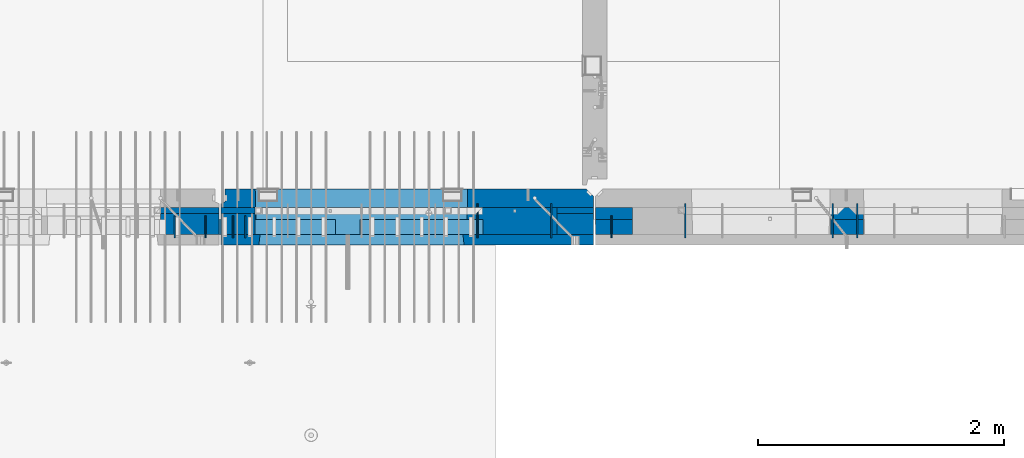
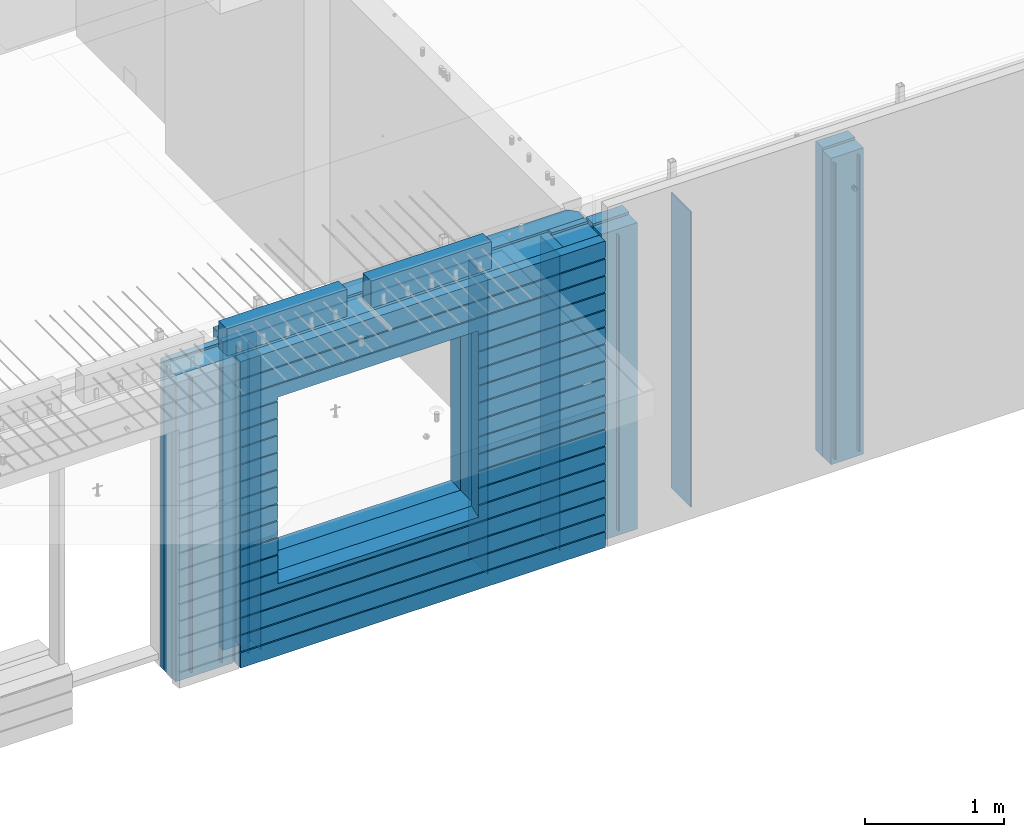
# One storey, part 198 of 309: 25 walls, 6 elements without a shape of their own.
"""IFC2X3 building model written with IfcOpenShell, lengths in millimetres."""

from ifc_helpers import new_model, si_unit, frame, origin_with_axes, place, context, subcontext, project, spatial, faceted_brep, material, type_object, element, aggregate, save


model = new_model("IFC2X3")

# Units and contexts
model_context = context("Model", 3, precision=1e-05, world=origin_with_axes())
body_context = subcontext(model_context, "Body", "Model", "MODEL_VIEW")
ifc_project = project(units=[si_unit("LENGTHUNIT", "METRE", prefix="MILLI"), si_unit("AREAUNIT", "SQUARE_METRE"), si_unit("VOLUMEUNIT", "CUBIC_METRE"), si_unit("MASSUNIT", "GRAM", prefix="KILO"), si_unit("TIMEUNIT", "SECOND"), si_unit("PLANEANGLEUNIT", "RADIAN"), si_unit("SOLIDANGLEUNIT", "STERADIAN"), si_unit("THERMODYNAMICTEMPERATUREUNIT", "DEGREE_CELSIUS"), si_unit("LUMINOUSINTENSITYUNIT", "LUMEN")], contexts=[model_context])

# Site, building, storey
site_placement = place(None, origin_with_axes())
site = spatial("IfcSite", under=ifc_project, at=site_placement, CompositionType="ELEMENT")
building_placement = place(site_placement, origin_with_axes())
building = spatial("IfcBuilding", under=site, at=building_placement, CompositionType="ELEMENT")
storey_placement = place(building_placement, origin_with_axes())
storey = spatial("IfcBuildingStorey", under=building, at=storey_placement, Name="7", CompositionType="ELEMENT", Elevation=0.0)

# Assembly, walls
assembly_1_placement = place(storey_placement, origin_with_axes())
assembly_1 = element("IfcElementAssembly", 1, at=assembly_1_placement, inside=storey, AssemblyPlace="NOTDEFINED", PredefinedType="REINFORCEMENT_UNIT")
ifc_material_1 = material(Name="Undefined")
wall_type_1 = type_object("IfcWallType", PredefinedType="NOTDEFINED")
wall_1_placement = place(assembly_1_placement, frame((25665.0, 7780.0, 101115.0), z_axis=(0.0, 0.0, 1.0), x_axis=(0.0, -1.0, 0.0)))
wall_1 = element("IfcWall", 2, at=wall_1_placement, type_object=wall_type_1, material=ifc_material_1, Name="(PD)", context=body_context, shape_type="Brep", body=[
    faceted_brep([(0.0, 5.0, -1300.0), (0.0, 5.0, 1300.0), (180.0, 5.0, 1300.0), (180.0, 5.0, -1300.0), (0.0, -5.0, 1300.0), (180.0, -5.0, 1300.0), (0.0, -5.0, -1300.0), (180.0, -5.0, -1300.0)], [[[0, 1, 2, 3]], [[1, 4, 5, 2]], [[4, 6, 7, 5]], [[6, 0, 3, 7]], [[5, 7, 3, 2]], [[6, 4, 1, 0]]]),
])
wall_2_placement = place(assembly_1_placement, frame((25765.0, 7780.0, 101115.0), z_axis=(0.0, 0.0, 1.0), x_axis=(0.0, -1.0, 0.0)))
wall_2 = element("IfcWall", 3, at=wall_2_placement, type_object=wall_type_1, material=ifc_material_1, Name="(PD)", context=body_context, shape_type="Brep", body=[
    faceted_brep([(0.0, 5.0, -1300.0), (0.0, 5.0, 1300.0), (180.0, 5.0, 1300.0), (180.0, 5.0, -1300.0), (0.0, -5.0, 1300.0), (180.0, -5.0, 1300.0), (0.0, -5.0, -1300.0), (180.0, -5.0, -1300.0)], [[[0, 1, 2, 3]], [[1, 4, 5, 2]], [[4, 6, 7, 5]], [[6, 0, 3, 7]], [[5, 7, 3, 2]], [[6, 4, 1, 0]]]),
])
wall_3_placement = place(assembly_1_placement, frame((28255.0, 7880.0, 101115.0), z_axis=(0.0, 0.0, 1.0), x_axis=(0.0, -1.0, 0.0)))
wall_3 = element("IfcWall", 4, at=wall_3_placement, type_object=wall_type_1, material=ifc_material_1, Name="(PD)", context=body_context, shape_type="Brep", body=[
    faceted_brep([(0.0, 5.0, -1300.0), (0.0, 5.0, 1300.0), (280.0, 5.0, 1300.0), (280.0, 5.0, -1300.0), (0.0, -5.0, 1300.0), (280.0, -5.0, 1300.0), (0.0, -5.0, -1300.0), (280.0, -5.0, -1300.0)], [[[0, 1, 2, 3]], [[1, 4, 5, 2]], [[4, 6, 7, 5]], [[6, 0, 3, 7]], [[5, 7, 3, 2]], [[6, 4, 1, 0]]]),
])

assembly_2_placement = place(storey_placement, origin_with_axes())
assembly_2 = element("IfcElementAssembly", 5, at=assembly_2_placement, inside=storey, AssemblyPlace="NOTDEFINED", PredefinedType="REINFORCEMENT_UNIT")
wall_4_placement = place(assembly_2_placement, frame((28745.0021834468, 7780.0, 101115.0), z_axis=(0.0, 0.0, 1.0), x_axis=(0.0, -1.0, 0.0)))
wall_4 = element("IfcWall", 6, at=wall_4_placement, type_object=wall_type_1, material=ifc_material_1, Name="(PD)", context=body_context, shape_type="Brep", body=[
    faceted_brep([(0.0, 5.0, -1300.0), (0.0, 5.0, 1300.0), (180.0, 5.0, 1300.0), (180.0, 5.0, -1300.0), (0.0, -5.0, 1300.0), (180.0, -5.0, 1300.0), (0.0, -5.0, -1300.0), (180.0, -5.0, -1300.0)], [[[0, 1, 2, 3]], [[1, 4, 5, 2]], [[4, 6, 7, 5]], [[6, 0, 3, 7]], [[5, 7, 3, 2]], [[6, 4, 1, 0]]]),
])
wall_5_placement = place(assembly_2_placement, frame((29345.0021834468, 7880.0, 101115.0), z_axis=(0.0, 0.0, 1.0), x_axis=(0.0, -1.0, 0.0)))
wall_5 = element("IfcWall", 7, at=wall_5_placement, type_object=wall_type_1, material=ifc_material_1, Name="(PD)", context=body_context, shape_type="Brep", body=[
    faceted_brep([(0.0, 5.0, -1300.0), (0.0, 5.0, 1300.0), (280.0, 5.0, 1300.0), (280.0, 5.0, -1300.0), (0.0, -5.0, 1300.0), (280.0, -5.0, 1300.0), (0.0, -5.0, -1300.0), (280.0, -5.0, -1300.0)], [[[0, 1, 2, 3]], [[1, 4, 5, 2]], [[4, 6, 7, 5]], [[6, 0, 3, 7]], [[5, 7, 3, 2]], [[6, 4, 1, 0]]]),
])
wall_6_placement = place(assembly_2_placement, frame((30545.0021834468, 7880.0, 101115.0), z_axis=(0.0, 0.0, 1.0), x_axis=(0.0, -1.0, 0.0)))
wall_6 = element("IfcWall", 8, at=wall_6_placement, type_object=wall_type_1, material=ifc_material_1, Name="(PD)", context=body_context, shape_type="Brep", body=[
    faceted_brep([(0.0, 5.0, -1300.0), (0.0, 5.0, 1300.0), (280.0, 5.0, 1300.0), (280.0, 5.0, -1300.0), (0.0, -5.0, 1300.0), (280.0, -5.0, 1300.0), (0.0, -5.0, -1300.0), (280.0, -5.0, -1300.0)], [[[0, 1, 2, 3]], [[1, 4, 5, 2]], [[4, 6, 7, 5]], [[6, 0, 3, 7]], [[5, 7, 3, 2]], [[6, 4, 1, 0]]]),
])
wall_7_placement = place(assembly_2_placement, frame((30745.0021834468, 7880.0, 101115.0), z_axis=(0.0, 0.0, 1.0), x_axis=(0.0, -1.0, 0.0)))
wall_7 = element("IfcWall", 9, at=wall_7_placement, type_object=wall_type_1, material=ifc_material_1, Name="(PD)", context=body_context, shape_type="Brep", body=[
    faceted_brep([(0.0, 5.0, -1300.0), (0.0, 5.0, 1300.0), (280.0, 5.0, 1300.0), (280.0, 5.0, -1300.0), (0.0, -5.0, 1300.0), (280.0, -5.0, 1300.0), (0.0, -5.0, -1300.0), (280.0, -5.0, -1300.0)], [[[0, 1, 2, 3]], [[1, 4, 5, 2]], [[4, 6, 7, 5]], [[6, 0, 3, 7]], [[5, 7, 3, 2]], [[6, 4, 1, 0]]]),
])

assembly_3_placement = place(storey_placement, origin_with_axes())
assembly_3 = element("IfcElementAssembly", 10, at=assembly_3_placement, inside=storey, AssemblyPlace="NOTDEFINED", PredefinedType="REINFORCEMENT_UNIT")
wall_8_placement = place(assembly_3_placement, frame((25190.0, 7780.0, 101115.0), z_axis=(0.0, 0.0, 1.0), x_axis=(0.0, -1.0, 0.0)))
wall_8 = element("IfcWall", 11, at=wall_8_placement, type_object=wall_type_1, material=ifc_material_1, Name="(PD)", context=body_context, shape_type="Brep", body=[
    faceted_brep([(0.0, 5.0, -1300.0), (0.0, 5.0, 1300.0), (180.0, 5.0, 1300.0), (180.0, 5.0, -1300.0), (0.0, -5.0, 1300.0), (180.0, -5.0, 1300.0), (0.0, -5.0, -1300.0), (180.0, -5.0, -1300.0)], [[[0, 1, 2, 3]], [[1, 4, 5, 2]], [[4, 6, 7, 5]], [[6, 0, 3, 7]], [[5, 7, 3, 2]], [[6, 4, 1, 0]]]),
])
wall_9_placement = place(assembly_3_placement, frame((25440.0, 7780.0, 101115.0), z_axis=(0.0, 0.0, 1.0), x_axis=(0.0, -1.0, 0.0)))
wall_9 = element("IfcWall", 12, at=wall_9_placement, type_object=wall_type_1, material=ifc_material_1, Name="(PD)", context=body_context, shape_type="Brep", body=[
    faceted_brep([(0.0, 5.0, -1300.0), (0.0, 5.0, 1300.0), (180.0, 5.0, 1300.0), (180.0, 5.0, -1300.0), (0.0, -5.0, 1300.0), (180.0, -5.0, 1300.0), (0.0, -5.0, -1300.0), (180.0, -5.0, -1300.0)], [[[0, 1, 2, 3]], [[1, 4, 5, 2]], [[4, 6, 7, 5]], [[6, 0, 3, 7]], [[5, 7, 3, 2]], [[6, 4, 1, 0]]]),
])

# Wall
wall_10_placement = place(assembly_1_placement, frame((27655.0, 7880.0, 101115.0), z_axis=(0.0, 0.0, 1.0), x_axis=(0.0, -1.0, 0.0)))
wall_10 = element("IfcWall", 13, at=wall_10_placement, type_object=wall_type_1, material=ifc_material_1, Name="(PD)", context=body_context, shape_type="Brep", body=[
    faceted_brep([(0.0, 5.0, -1300.0), (0.0, 5.0, 1300.0), (280.0, 5.0, 1300.0), (280.0, 5.0, -1300.0), (0.0, -5.0, 1300.0), (280.0, -5.0, 1300.0), (0.0, -5.0, -1300.0), (280.0, -5.0, -1300.0)], [[[0, 1, 2, 3]], [[1, 4, 5, 2]], [[4, 6, 7, 5]], [[6, 0, 3, 7]], [[5, 7, 3, 2]], [[6, 4, 1, 0]]]),
])

# Assemblies, walls
assembly_4_placement = place(storey_placement, origin_with_axes())
assembly_4 = element("IfcElementAssembly", 14, at=assembly_4_placement, inside=storey, AssemblyPlace="NOTDEFINED", PredefinedType="REINFORCEMENT_UNIT")
assembly_5_placement = place(assembly_4_placement, origin_with_axes())
assembly_5 = element("IfcElementAssembly", 15, at=assembly_5_placement, Name="Steel Assembly", AssemblyPlace="NOTDEFINED", PredefinedType="NOTDEFINED")
ifc_material_2 = material()
wall_type_2 = type_object("IfcWallType", PredefinedType="NOTDEFINED")
wall_11_placement = place(assembly_5_placement, frame((26699.9998568133, 7690.00021946163, 102590.0), z_axis=(0.0, 0.0, 1.0), x_axis=(1.0, 0.0, 0.0)))
wall_11 = element("IfcWall", 16, at=wall_11_placement, type_object=wall_type_2, material=ifc_material_2, context=body_context, shape_type="Brep", body=[
    faceted_brep([(0.0, 60.0, -120.0), (0.0, 60.0, 120.0), (1000.0, 60.0, 120.0), (1000.0, 60.0, -120.0), (0.0, -60.0, 120.0), (1000.0, -60.0, 120.0), (0.0, -60.0, -120.0), (1000.0, -60.0, -120.0)], [[[0, 1, 2, 3]], [[1, 4, 5, 2]], [[4, 6, 7, 5]], [[6, 0, 3, 7]], [[5, 7, 3, 2]], [[6, 4, 1, 0]]]),
])
aggregate(assembly_5, [wall_11])
assembly_6_placement = place(assembly_4_placement, origin_with_axes())
assembly_6 = element("IfcElementAssembly", 17, at=assembly_6_placement, Name="Steel Assembly", AssemblyPlace="NOTDEFINED", PredefinedType="NOTDEFINED")
aggregate(assembly_4, [assembly_5, assembly_6])
wall_12_placement = place(assembly_6_placement, frame((25499.9998568133, 7690.00021946163, 102590.0), z_axis=(0.0, 0.0, 1.0), x_axis=(1.0, 0.0, 0.0)))
wall_12 = element("IfcWall", 18, at=wall_12_placement, type_object=wall_type_2, material=ifc_material_2, context=body_context, shape_type="Brep", body=[
    faceted_brep([(0.0, 60.0, -120.0), (0.0, 60.0, 120.0), (1000.0, 60.0, 120.0), (1000.0, 60.0, -120.0), (0.0, -60.0, 120.0), (1000.0, -60.0, 120.0), (0.0, -60.0, -120.0), (1000.0, -60.0, -120.0)], [[[0, 1, 2, 3]], [[1, 4, 5, 2]], [[4, 6, 7, 5]], [[6, 0, 3, 7]], [[5, 7, 3, 2]], [[6, 4, 1, 0]]]),
])
aggregate(assembly_6, [wall_12])

# Wall
ifc_material_3 = material(Name="CONCRETE/C35/45")
wall_type_3 = type_object("IfcWallType", PredefinedType="NOTDEFINED")
wall_13_placement = place(assembly_1_placement, frame((28600.0, 7925.0, 101112.5), z_axis=(0.0, 0.0, 1.0), x_axis=(-1.0, 3.00000001838171e-08, 0.0)))
wall_13 = element("IfcWall", 19, at=wall_13_placement, type_object=wall_type_3, material=ifc_material_3, context=body_context, shape_type="Brep", body=[
    faceted_brep([(0.0, 75.0, 1357.5), (0.0, 75.0, -1357.5), (0.0, -15.0, -1357.5), (0.0, -15.0, 1357.5), (60.0, -75.0, -1357.5), (3035.00000000003, 75.0, -1357.5), (3035.00000000003, 45.0, -1357.5), (3002.5, 32.0, -1357.5), (3002.5, -75.0, -1357.5), (60.0, -75.0, 1357.5), (3035.00000000003, 45.0, 1357.5), (3035.00000000003, 75.0, 1357.5), (3002.5, -75.0, 1357.5), (3002.5, 32.0, 1357.5), (2755.00051719707, -75.0, -682.5), (1025.00051719707, -75.0, -682.5), (1025.00051719707, -75.0, 952.5), (2755.00051719707, -75.0, 952.5), (2750.94646314301, 75.0, -678.445945945947), (1029.05457125112, 75.0, -678.445945945947), (1029.05457125112, 75.0, 948.445945945947), (2750.94646314301, 75.0, 948.445945945947)], [[[0, 1, 2, 3]], [[4, 2, 1, 5, 6, 7, 8]], [[3, 2, 4, 9]], [[10, 11, 0, 3, 9, 12, 13]], [[5, 11, 10, 6]], [[13, 7, 6, 10]], [[12, 8, 7, 13]], [[9, 4, 8, 12], [14, 15, 16, 17]], [[14, 18, 19, 15]], [[15, 19, 20, 16]], [[1, 0, 11, 5], [18, 21, 20, 19]], [[16, 20, 21, 17]], [[18, 14, 17, 21]]]),
])

wall_type_4 = type_object("IfcWallType", PredefinedType="NOTDEFINED")
wall_14_placement = place(assembly_2_placement, frame((30795.0000381475, 7800.0, 101112.5), z_axis=(0.0, 0.0, 1.0), x_axis=(-1.0, 3.00000001838171e-08, 0.0)))
wall_14 = element("IfcWall", 20, at=wall_14_placement, type_object=wall_type_4, material=ifc_material_3, context=body_context, shape_type="Brep", body=[
    faceted_brep([(0.0, 50.0, -1357.5), (0.0, 50.0, 1357.5), (270.001908754726, 50.0, 1357.5), (270.001908754726, 50.0, -1357.5), (0.0, -50.0, 1357.5), (270.001908754726, -50.0, 1357.5), (0.0, -50.0, -1357.5), (270.001908754726, -50.0, -1357.5)], [[[0, 1, 2, 3]], [[1, 4, 5, 2]], [[4, 6, 7, 5]], [[6, 0, 3, 7]], [[5, 7, 3, 2]], [[6, 4, 1, 0]]]),
])

wall_15_placement = place(assembly_2_placement, frame((28915.0000381475, 7800.0, 101112.5), z_axis=(0.0, 0.0, 1.0), x_axis=(-1.0, 3.00000001838171e-08, 0.0)))
wall_15 = element("IfcWall", 21, at=wall_15_placement, type_object=wall_type_4, material=ifc_material_3, context=body_context, shape_type="Brep", body=[
    faceted_brep([(0.0, 50.0, -1357.5), (0.0, 50.0, 1357.5), (300.001908754726, 50.0, 1357.5), (300.001908754726, 50.0, -1357.5), (0.0, -50.0, 1357.5), (300.001908754726, -50.0, 1357.5), (0.0, -50.0, -1357.5), (300.001908754726, -50.0, -1357.5)], [[[0, 1, 2, 3]], [[1, 4, 5, 2]], [[4, 6, 7, 5]], [[6, 0, 3, 7]], [[5, 7, 3, 2]], [[6, 4, 1, 0]]]),
])

ifc_material_4 = material(Name="SPU")
wall_type_5 = type_object("IfcWallType", PredefinedType="NOTDEFINED")
wall_16_placement = place(assembly_2_placement, frame((30795.0000381475, 7690.0, 101102.5), z_axis=(0.0, 0.0, 1.0), x_axis=(-1.0, 3.00000001838171e-08, 0.0)))
wall_16 = element("IfcWall", 22, at=wall_16_placement, type_object=wall_type_5, material=ifc_material_4, context=body_context, shape_type="Brep", body=[
    faceted_brep([(0.0, 60.0, -1347.5), (0.0, 60.0, 1347.5), (270.001908754726, 60.0, 1347.5), (270.001908754726, 60.0, -1347.5), (0.0, -60.0, 1347.5), (270.001908754726, -60.0, 1347.5), (0.0, -60.0, -1347.5), (270.001908754726, -60.0, -1347.5)], [[[0, 1, 2, 3]], [[1, 4, 5, 2]], [[4, 6, 7, 5]], [[6, 0, 3, 7]], [[5, 7, 3, 2]], [[6, 4, 1, 0]]]),
])

wall_17_placement = place(assembly_2_placement, frame((28915.0000381475, 7690.0, 101102.5), z_axis=(0.0, 0.0, 1.0), x_axis=(-1.0, 3.00000001838171e-08, 0.0)))
wall_17 = element("IfcWall", 23, at=wall_17_placement, type_object=wall_type_5, material=ifc_material_4, context=body_context, shape_type="Brep", body=[
    faceted_brep([(0.0, 60.0, -1347.5), (0.0, 60.0, 1347.5), (300.001908754726, 60.0, 1347.5), (300.001908754726, 60.0, -1347.5), (0.0, -60.0, 1347.5), (300.001908754726, -60.0, 1347.5), (0.0, -60.0, -1347.5), (300.001908754726, -60.0, -1347.5)], [[[0, 1, 2, 3]], [[1, 4, 5, 2]], [[4, 6, 7, 5]], [[6, 0, 3, 7]], [[5, 7, 3, 2]], [[6, 4, 1, 0]]]),
])

aggregate(assembly_2, [wall_16, wall_14, wall_17, wall_15, wall_4, wall_5, wall_6, wall_7])

wall_type_6 = type_object("IfcWallType", PredefinedType="NOTDEFINED")
wall_18_placement = place(assembly_1_placement, frame((28600.0000381475, 7825.0, 101112.5), z_axis=(0.0, 0.0, 1.0), x_axis=(-1.0, 3.00000001838171e-08, 0.0)))
wall_18 = element("IfcWall", 24, at=wall_18_placement, type_object=wall_type_6, material=ifc_material_3, context=body_context, shape_type="Brep", body=[
    faceted_brep([(0.0, 25.0, -1357.5), (0.0, 25.0, 1357.5), (300.001908754726, 25.0, 1357.5), (300.001908754726, 25.0, -1357.5), (0.0, -25.0, 1357.5), (300.001908754726, -25.0, 1357.5), (0.0, -25.0, -1357.5), (300.001908754726, -25.0, -1357.5)], [[[0, 1, 2, 3]], [[1, 4, 5, 2]], [[4, 6, 7, 5]], [[6, 0, 3, 7]], [[5, 7, 3, 2]], [[6, 4, 1, 0]]]),
])

wall_19_placement = place(assembly_3_placement, frame((25550.0000381475, 7825.00011629906, 101112.5), z_axis=(0.0, 0.0, 1.0), x_axis=(-1.0, 3.00000001838171e-08, 0.0)))
wall_19 = element("IfcWall", 25, at=wall_19_placement, type_object=wall_type_6, material=ifc_material_3, context=body_context, shape_type="Brep", body=[
    faceted_brep([(0.0, 25.0, -1357.5), (0.0, 25.0, 1357.5), (475.001908754726, 25.0, 1357.5), (475.001908754726, 25.0, -1357.5), (0.0, -25.0, 1357.5), (475.001908754726, -25.0, 1357.5), (0.0, -25.0, -1357.5), (475.001908754726, -25.0, -1357.5)], [[[0, 1, 2, 3]], [[1, 4, 5, 2]], [[4, 6, 7, 5]], [[6, 0, 3, 7]], [[5, 7, 3, 2]], [[6, 4, 1, 0]]]),
])

wall_20_placement = place(assembly_1_placement, frame((25845.0000381475, 7825.0, 101112.5), z_axis=(0.0, 0.0, 1.0), x_axis=(-1.0, 3.00000001838171e-08, 0.0)))
wall_20 = element("IfcWall", 26, at=wall_20_placement, type_object=wall_type_6, material=ifc_material_3, context=body_context, shape_type="Brep", body=[
    faceted_brep([(0.0, 25.0, -1357.5), (0.0, 25.0, 1357.5), (280.001908754726, 25.0, 1357.5), (280.001908754726, 25.0, -1357.5), (0.0, -25.0, 1357.5), (280.001908754726, -25.0, 1357.5), (0.0, -25.0, -1357.5), (280.001908754726, -25.0, -1357.5)], [[[0, 1, 2, 3]], [[1, 4, 5, 2]], [[4, 6, 7, 5]], [[6, 0, 3, 7]], [[5, 7, 3, 2]], [[6, 4, 1, 0]]]),
])

wall_type_7 = type_object("IfcWallType", PredefinedType="NOTDEFINED")
wall_21_placement = place(assembly_3_placement, frame((25550.0000381475, 7715.00011629906, 101102.5), z_axis=(0.0, 0.0, 1.0), x_axis=(-1.0, 3.00000001838171e-08, 0.0)))
wall_21 = element("IfcWall", 27, at=wall_21_placement, type_object=wall_type_7, material=ifc_material_4, context=body_context, shape_type="Brep", body=[
    faceted_brep([(0.0, 85.0, -1347.5), (0.0, 85.0, 1347.5), (475.001908754726, 85.0, 1347.5), (475.001908754726, 85.0, -1347.5), (0.0, -85.0, 1347.5), (475.001908754726, -85.0, 1347.5), (0.0, -85.0, -1347.5), (475.001908754726, -85.0, -1347.5)], [[[0, 1, 2, 3]], [[1, 4, 5, 2]], [[4, 6, 7, 5]], [[6, 0, 3, 7]], [[5, 7, 3, 2]], [[6, 4, 1, 0]]]),
])

aggregate(assembly_3, [wall_21, wall_19, wall_8, wall_9])

wall_22_placement = place(assembly_1_placement, frame((28600.0000381475, 7715.0, 101102.5), z_axis=(0.0, 0.0, 1.0), x_axis=(-1.0, 3.00000001838171e-08, 0.0)))
wall_22 = element("IfcWall", 28, at=wall_22_placement, type_object=wall_type_7, material=ifc_material_4, context=body_context, shape_type="Brep", body=[
    faceted_brep([(0.0, 85.0, -1347.5), (0.0, 85.0, 1347.5), (300.001908754726, 85.0, 1347.5), (300.001908754726, 85.0, -1347.5), (0.0, -85.0, 1347.5), (300.001908754726, -85.0, 1347.5), (0.0, -85.0, -1347.5), (300.001908754726, -85.0, -1347.5)], [[[0, 1, 2, 3]], [[1, 4, 5, 2]], [[4, 6, 7, 5]], [[6, 0, 3, 7]], [[5, 7, 3, 2]], [[6, 4, 1, 0]]]),
])

wall_23_placement = place(assembly_1_placement, frame((25845.0000381475, 7715.0, 101102.5), z_axis=(0.0, 0.0, 1.0), x_axis=(-1.0, 3.00000001838171e-08, 0.0)))
wall_23 = element("IfcWall", 29, at=wall_23_placement, type_object=wall_type_7, material=ifc_material_4, context=body_context, shape_type="Brep", body=[
    faceted_brep([(0.0, 85.0, -1347.5), (0.0, 85.0, 1347.5), (280.001908754726, 85.0, 1347.5), (280.001908754726, 85.0, -1347.5), (0.0, -85.0, 1347.5), (280.001908754726, -85.0, 1347.5), (0.0, -85.0, -1347.5), (280.001908754726, -85.0, -1347.5)], [[[0, 1, 2, 3]], [[1, 4, 5, 2]], [[4, 6, 7, 5]], [[6, 0, 3, 7]], [[5, 7, 3, 2]], [[6, 4, 1, 0]]]),
])

ifc_material_5 = material(Name="CONCRETE/C30/37")
wall_type_8 = type_object("IfcWallType", PredefinedType="NOTDEFINED")
wall_24_placement = place(assembly_1_placement, frame((28600.0, 7587.5, 101102.5), z_axis=(0.0, 0.0, 1.0), x_axis=(-1.0, 3.00000001838171e-08, 0.0)))
wall_24 = element("IfcWall", 30, at=wall_24_placement, type_object=wall_type_8, material=ifc_material_5, context=body_context, shape_type="Brep", body=[
    faceted_brep([(3.63797880709171e-12, 32.4999991119639, 1050.00000040043), (3035.0, 32.4999991119785, 1050.00000040044), (3035.0, 32.4999992499725, 1039.99999999921), (3.63797880709171e-12, 32.4999992499725, 1039.99999999921), (0.0, 42.5, 1051.99999988925), (3035.0, 42.5, 1051.99999988925), (0.0, 42.5, 1187.99999994476), (3035.0, 42.5, 1187.99999994476), (-3.63797880709171e-12, 32.499999249967, 1189.99999999923), (3035.0, 32.4999992499634, 1189.99999999921), (-3.63797880709171e-12, 32.4999991119576, 1200.00000040043), (3035.0, 32.4999991119703, 1200.00000040044), (0.0, 42.5, 1201.99999988925), (3035.0, 42.5, 1201.99999988925), (0.0, 42.5, 1347.5), (3035.0, 42.5, 1347.5), (0.0, -42.5, 1347.5), (3035.0, -42.5, 1347.5), (0.0, -42.5, -1347.5), (0.0, 42.5, -1347.5), (3035.0, 42.5, -1347.5), (3035.0, -42.5, -1347.5), (0.0, 42.5, -1212.00000005524), (3035.0, 42.5, -1212.00000005524), (0.0, 32.4999992501671, -1210.00000000079), (3035.0, 32.4999992501644, -1210.0000000008), (0.0, 32.4999991121604, -1199.99999959957), (3035.0, 32.4999991121604, -1199.99999959957), (0.0, 42.5, -1198.00000011075), (3035.0, 42.5, -1198.00000011075), (0.0, 42.5, -1062.00000005522), (3035.0, 42.5, -1062.00000005522), (0.0, 32.4999992506973, -1060.00000000076), (3035.0, 32.4999992506928, -1060.00000000079), (0.0, 32.4999991126861, -1049.99999959956), (3035.0, 32.4999991126924, -1049.99999959956), (0.0, 42.5, -1048.00000011074), (3035.0, 42.5, -1048.00000011074), (0.0, 42.5, -912.000000055254), (3035.0, 42.5, -912.000000055254), (0.0, 32.4999992512376, -910.000000000786), (3035.0, 32.4999992512339, -910.000000000815), (0.0, 32.499999113239, -899.99999959959), (3035.0, 32.4999991132327, -899.99999959959), (0.0, 42.5, -898.000000110769), (3035.0, 42.5, -898.000000110769), (0.0, 42.5, -762.000000055225), (3035.0, 42.5, -762.000000055225), (0.0, 32.4999992517696, -760.000000000757), (3035.0, 32.499999251766, -760.000000000786), (0.0, 32.4999991137702, -749.99999959956), (3035.0, 32.4999991137656, -749.99999959956), (0.0, 42.5, -748.00000011074), (3035.0, 42.5, -748.00000011074), (3035.0, 42.5, 901.999999889245), (3035.0, 32.4999991119894, 900.00000040044), (2723.82404650436, 32.4999991119894, 900.00000040044), (2725.00051719707, 42.5, 901.999999889245), (3035.0, 32.4999992499834, 889.999999999214), (2723.82404652059, 32.4999992499834, 889.999999999214), (3035.0, 42.5, 887.999999944761), (2725.00051719707, 42.5, 887.999999944761), (3035.0, 42.5, 751.999999889245), (2725.00051719707, 42.5, 751.999999889245), (3035.0, 32.4999991119967, 750.000000400425), (2723.82404650436, 32.4999991119967, 750.000000400425), (3035.0, 32.4999992499961, 739.9999999992), (2723.82404652059, 32.4999992499961, 739.9999999992), (3035.0, 42.5, 737.999999944761), (2725.00051719707, 42.5, 737.999999944761), (3035.0, 42.5, 601.99999988926), (2725.00051719707, 42.5, 601.99999988926), (3035.0, 32.4999991120212, 600.000000400454), (2723.82404650436, 32.4999991120212, 600.000000400454), (3035.0, 32.4999992500161, 589.999999999229), (2723.8240465206, 32.4999992500161, 589.999999999229), (3035.0, 42.5, 587.999999944775), (2725.00051719707, 42.5, 587.999999944775), (3035.0, 42.5, 451.999999889231), (2725.00051719707, 42.5, 451.999999889231), (3035.0, 32.4999991120285, 450.000000400425), (2723.82404650436, 32.4999991120285, 450.000000400425), (3035.0, 32.4999992500234, 439.9999999992), (2723.8240465206, 32.4999992500234, 439.9999999992), (3035.0, 42.5, 437.999999944746), (2725.00051719707, 42.5, 437.999999944746), (3035.0, 42.5, 301.999999889245), (2725.00051719707, 42.5, 301.999999889245), (3035.0, 32.4999991120458, 300.00000040044), (2723.82404650437, 32.4999991120458, 300.00000040044), (3035.0, 32.4999992500389, 289.999999999214), (2723.8240465206, 32.4999992500389, 289.999999999214), (3035.0, 42.5, 287.999999944761), (2725.00051719707, 42.5, 287.999999944761), (3035.0, 42.5, 151.99999988926), (2725.00051719707, 42.5, 151.99999988926), (3035.0, 32.4999991120585, 150.000000400454), (2723.82404650437, 32.4999991120585, 150.000000400454), (3035.0, 32.4999992500534, 139.999999999229), (2723.8240465206, 32.4999992500534, 139.999999999229), (3035.0, 42.5, 137.999999944775), (2725.00051719707, 42.5, 137.999999944775), (3035.0, 42.5, 1.99999988924537), (2725.00051719707, 42.5, 1.99999988924537), (3035.0, 32.4999992522926, -610.0000000008), (3035.0, 42.5, -612.000000055239), (2725.00051719707, 42.5, -612.000000055239), (2723.82404652087, 32.4999992522926, -610.0000000008), (3035.0, 32.4999991142904, -599.999999599575), (2723.82404650463, 32.4999991142904, -599.999999599575), (3035.0, 42.5, -598.000000110755), (2725.00051719707, 42.5, -598.000000110755), (3035.0, 42.5, -462.000000055239), (2725.00051719707, 42.5, -462.000000055239), (3035.0, 32.4999992528319, -460.0000000008), (2723.82404652093, 32.4999992528319, -460.0000000008), (3035.0, 32.4999991148297, -449.999999599575), (2723.82404650469, 32.4999991148297, -449.999999599575), (3035.0, 42.5, -448.000000110755), (2725.00051719707, 42.5, -448.000000110755), (3035.0, 42.5, -312.000000055254), (2725.00051719707, 42.5, -312.000000055254), (3035.0, 32.4999992533585, -310.000000000815), (2723.82404652099, 32.4999992533585, -310.000000000815), (3035.0, 32.4999991153563, -299.99999959959), (2723.82404650475, 32.4999991153563, -299.99999959959), (3035.0, 42.5, -298.000000110769), (2725.00051719707, 42.5, -298.000000110769), (3035.0, 42.5, -162.000000055239), (2725.00051719707, 42.499999923677, -162.000000055239), (3035.0, 32.4999992538951, -160.0000000008), (2723.82404652105, 32.4999992538951, -160.0000000008), (3035.0, 32.4999991158938, -149.999999599575), (2723.82404650482, 32.4999991158938, -149.999999599575), (3035.0, 42.5, -148.000000110755), (2725.00051719707, 42.4999999210722, -148.000000110755), (3035.0, 42.5, -12.0000000552391), (2725.00051719707, 42.5, -12.0000000552391), (3035.0, 32.4999992538906, -10.0000000008004), (2723.82404652105, 32.4999992538906, -10.0000000008004), (3035.0, 32.4999991158902, 4.00425051338971e-07), (2723.82404650482, 32.4999991158902, 4.00425051338971e-07), (3035.0, 42.5, 1037.99999994476), (0.0, 42.5, 1037.99999994476), (3.63797880709171e-12, 32.4999992499852, 889.999999999229), (3.63797880709171e-12, 32.4999991119857, 900.000000400425), (1056.17698788978, 32.4999991119894, 900.00000040044), (1056.17698787354, 32.4999992499834, 889.999999999214), (0.0, 42.5, 887.999999944761), (1055.00051719707, 42.5, 887.999999944761), (0.0, 42.5, 751.999999889245), (1055.00051719707, 42.5, 751.999999889245), (0.0, 32.4999991120039, 750.00000040044), (1056.17698788978, 32.4999991119967, 750.000000400425), (0.0, 32.4999992499997, 739.999999999229), (1056.17698787354, 32.4999992499961, 739.9999999992), (0.0, 42.5, 737.999999944761), (1055.00051719707, 42.5, 737.999999944761), (0.0, 42.5, 601.99999988926), (1055.00051719707, 42.5, 601.99999988926), (0.0, 32.4999991120094, 600.00000040044), (1056.17698788977, 32.4999991120212, 600.000000400454), (0.0, 32.499999250017, 589.999999999229), (1056.17698787354, 32.4999992500161, 589.999999999229), (0.0, 42.5, 587.999999944775), (1055.00051719707, 42.5, 587.999999944775), (0.0, 42.5, 451.999999889231), (1055.00051719707, 42.5, 451.999999889231), (0.0, 32.4999991120258, 450.000000400411), (1056.17698788977, 32.4999991120285, 450.000000400425), (0.0, 32.4999992500289, 439.999999999214), (1056.17698787354, 32.4999992500234, 439.9999999992), (0.0, 42.5, 437.999999944746), (1055.00051719707, 42.5, 437.999999944746), (0.0, 42.5, 301.999999889245), (1055.00051719707, 42.5, 301.999999889245), (-3.63797880709171e-12, 32.4999991120458, 300.00000040044), (1056.17698788977, 32.4999991120458, 300.00000040044), (-3.63797880709171e-12, 32.4999992500416, 289.999999999229), (1056.17698787353, 32.4999992500389, 289.999999999214), (0.0, 42.5, 287.999999944761), (1055.00051719707, 42.5, 287.999999944761), (0.0, 42.5, 151.99999988926), (1055.00051719707, 42.5, 151.99999988926), (0.0, 32.4999991120549, 150.00000040044), (1056.17698788977, 32.4999991120585, 150.000000400454), (0.0, 32.4999992500552, 139.999999999229), (1056.17698787353, 32.4999992500534, 139.999999999229), (0.0, 42.5, 137.999999944775), (1055.00051719707, 42.5, 137.999999944775), (0.0, 42.5, 1.99999988924537), (1055.00051719707, 42.5, 1.99999988924537), (0.0, 42.5, -12.0000000552391), (0.0, 42.5, -148.000000110755), (0.0, 32.4999991158993, -149.99999959956), (0.0, 32.4999992538978, -160.000000000757), (0.0, 42.5, -162.000000055239), (0.0, 42.5, -298.000000110769), (0.0, 32.4999991153618, -299.99999959959), (0.0, 32.4999992533649, -310.000000000786), (0.0, 42.5, -312.000000055254), (0.0, 42.5, -448.000000110755), (0.0, 32.4999991148252, -449.999999599575), (0.0, 32.4999992528365, -460.000000000771), (0.0, 42.5, -462.000000055239), (0.0, 42.5, -598.000000110755), (0.0, 32.4999991143004, -599.99999959956), (0.0, 32.4999992522971, -610.000000000771), (0.0, 42.5, -612.000000055239), (0.0, 42.5, 901.999999889245), (0.0, 32.4999991158911, 4.00425051338971e-07), (0.0, 32.4999992538942, -10.0000000007858), (1056.17698788932, 32.4999991158902, 4.00425051338971e-07), (1056.17698787308, 32.4999992538906, -10.0000000008004), (1055.00051719707, 42.5, -12.0000000552391), (1055.00051719707, 42.4999994958771, -148.000000110755), (1056.17698788932, 32.4999991158938, -149.999999599575), (1056.17698787308, 32.4999992538951, -160.0000000008), (1055.00051719707, 42.499999512519, -162.000000055239), (1055.00051719707, 42.5, -298.000000110769), (1056.17698788938, 32.4999991153563, -299.99999959959), (1056.17698787315, 32.4999992533585, -310.000000000815), (1055.00051719707, 42.5, -312.000000055254), (1055.00051719707, 42.5, -448.000000110755), (1056.17698788944, 32.4999991148297, -449.999999599575), (1056.17698787321, 32.4999992528319, -460.0000000008), (1055.00051719707, 42.5, -462.000000055239), (1055.00051719707, 42.5, -598.000000110755), (1056.1769878895, 32.4999991142904, -599.999999599575), (1056.17698787327, 32.4999992522926, -610.0000000008), (1055.00051719707, 42.5, -612.000000055239), (2725.00051719707, 42.5, -712.5), (1055.00051719707, 42.5, -712.5), (2715.00051719707, -42.5, 927.5), (2715.00051719707, -42.5, 932.5), (2725.00051719707, 42.5, 927.5), (2715.00051719707, -42.5, -662.5), (1065.00051719707, -42.5, -662.5), (1065.00051719707, -42.5, 927.5), (1065.00051719707, -42.5, 932.5), (1065.00051719707, 42.5, 927.5), (2715.00051719707, 42.5, 927.5), (1055.00051719707, 42.5, 927.5), (1055.00051719707, 42.5, 901.999999889245)], [[[0, 1, 2, 3]], [[4, 5, 1, 0]], [[5, 4, 6, 7]], [[8, 9, 7, 6]], [[10, 11, 9, 8]], [[12, 13, 11, 10]], [[14, 15, 13, 12]], [[14, 16, 17, 15]], [[18, 19, 20, 21]], [[20, 19, 22, 23]], [[24, 25, 23, 22]], [[26, 27, 25, 24]], [[28, 29, 27, 26]], [[29, 28, 30, 31]], [[32, 33, 31, 30]], [[34, 35, 33, 32]], [[36, 37, 35, 34]], [[37, 36, 38, 39]], [[40, 41, 39, 38]], [[42, 43, 41, 40]], [[44, 45, 43, 42]], [[45, 44, 46, 47]], [[48, 49, 47, 46]], [[50, 51, 49, 48]], [[52, 53, 51, 50]], [[54, 55, 56, 57]], [[55, 58, 59, 56]], [[58, 60, 61, 59]], [[60, 62, 63, 61]], [[62, 64, 65, 63]], [[64, 66, 67, 65]], [[66, 68, 69, 67]], [[68, 70, 71, 69]], [[70, 72, 73, 71]], [[72, 74, 75, 73]], [[74, 76, 77, 75]], [[76, 78, 79, 77]], [[78, 80, 81, 79]], [[80, 82, 83, 81]], [[82, 84, 85, 83]], [[84, 86, 87, 85]], [[86, 88, 89, 87]], [[88, 90, 91, 89]], [[90, 92, 93, 91]], [[92, 94, 95, 93]], [[94, 96, 97, 95]], [[96, 98, 99, 97]], [[98, 100, 101, 99]], [[100, 102, 103, 101]], [[104, 105, 106, 107]], [[108, 104, 107, 109]], [[110, 108, 109, 111]], [[112, 110, 111, 113]], [[114, 112, 113, 115]], [[116, 114, 115, 117]], [[118, 116, 117, 119]], [[120, 118, 119, 121]], [[122, 120, 121, 123]], [[124, 122, 123, 125]], [[126, 124, 125, 127]], [[128, 126, 127, 129]], [[130, 128, 129, 131]], [[132, 130, 131, 133]], [[134, 132, 133, 135]], [[136, 134, 135, 137]], [[138, 136, 137, 139]], [[140, 138, 139, 141]], [[102, 140, 141, 103]], [[100, 98, 96, 94, 92, 90, 88, 86, 84, 82, 80, 78, 76, 74, 72, 70, 68, 66, 64, 62, 60, 58, 55, 54, 142, 2, 1, 5, 7, 9, 11, 13, 15, 17, 21, 20, 23, 25, 27, 29, 31, 33, 35, 37, 39, 41, 43, 45, 47, 49, 51, 53, 105, 104, 108, 110, 112, 114, 116, 118, 120, 122, 124, 126, 128, 130, 132, 134, 136, 138, 140, 102]], [[3, 2, 142, 143]], [[144, 145, 146, 147]], [[148, 144, 147, 149]], [[150, 148, 149, 151]], [[152, 150, 151, 153]], [[154, 152, 153, 155]], [[156, 154, 155, 157]], [[158, 156, 157, 159]], [[160, 158, 159, 161]], [[162, 160, 161, 163]], [[164, 162, 163, 165]], [[166, 164, 165, 167]], [[168, 166, 167, 169]], [[170, 168, 169, 171]], [[172, 170, 171, 173]], [[174, 172, 173, 175]], [[176, 174, 175, 177]], [[178, 176, 177, 179]], [[180, 178, 179, 181]], [[182, 180, 181, 183]], [[184, 182, 183, 185]], [[186, 184, 185, 187]], [[188, 186, 187, 189]], [[190, 188, 189, 191]], [[192, 193, 194, 195, 196, 197, 198, 199, 200, 201, 202, 203, 204, 205, 206, 207, 208, 52, 50, 48, 46, 44, 42, 40, 38, 36, 34, 32, 30, 28, 26, 24, 22, 19, 18, 16, 14, 12, 10, 8, 6, 4, 0, 3, 143, 209, 145, 144, 148, 150, 152, 154, 156, 158, 160, 162, 164, 166, 168, 170, 172, 174, 176, 178, 180, 182, 184, 186, 188, 190, 210, 211]], [[211, 210, 212, 213]], [[192, 211, 213, 214]], [[193, 192, 214, 215]], [[194, 193, 215, 216]], [[195, 194, 216, 217]], [[196, 195, 217, 218]], [[197, 196, 218, 219]], [[198, 197, 219, 220]], [[199, 198, 220, 221]], [[200, 199, 221, 222]], [[201, 200, 222, 223]], [[202, 201, 223, 224]], [[203, 202, 224, 225]], [[204, 203, 225, 226]], [[205, 204, 226, 227]], [[206, 205, 227, 228]], [[207, 206, 228, 229]], [[208, 207, 229, 230]], [[231, 106, 105, 53, 52, 208, 230, 232]], [[233, 234, 235, 57, 56, 59, 61, 63, 65, 67, 69, 71, 73, 75, 77, 79, 81, 83, 85, 87, 89, 91, 93, 95, 97, 99, 101, 103, 141, 139, 137, 135, 133, 131, 129, 127, 125, 123, 121, 119, 117, 115, 113, 111, 109, 107, 106, 231, 236]], [[232, 237, 236, 231]], [[16, 18, 21, 17], [233, 236, 237, 238, 239, 234]], [[240, 241, 235, 234, 239, 242]], [[209, 143, 142, 54, 57, 235, 241, 240, 242, 243]], [[145, 209, 243, 146]], [[242, 239, 238, 237, 232, 230, 229, 228, 227, 226, 225, 224, 223, 222, 221, 220, 219, 218, 217, 216, 215, 214, 213, 212, 191, 189, 187, 185, 183, 181, 179, 177, 175, 173, 171, 169, 167, 165, 163, 161, 159, 157, 155, 153, 151, 149, 147, 146, 243]], [[210, 190, 191, 212]]]),
])

ifc_material_6 = material(Name="COS5gt")
wall_type_9 = type_object("IfcWallType", PredefinedType="NOTDEFINED")
wall_25_placement = place(assembly_1_placement, frame((28600.0, 7740.0, 101102.5), z_axis=(0.0, 0.0, 1.0), x_axis=(-1.0, 3.00000001838171e-08, 0.0)))
wall_25 = element("IfcWall", 31, at=wall_25_placement, type_object=wall_type_9, material=ifc_material_6, context=body_context, shape_type="Brep", body=[
    faceted_brep([(2755.0, 90.0, -1347.5), (2755.0, -110.0, -1347.5), (300.001870607201, -110.0, -1347.5), (300.001870607201, 90.0, -1347.5), (2755.0, 90.0, -1297.5), (300.001870607201, 90.0, -1297.5), (2755.0, 110.0, -1297.5), (300.001870607201, 110.0, -1297.5), (2755.0, 110.0, 1347.5), (2755.0, -110.0, 1347.5), (2750.94646314301, -110.0, -668.445945945947), (2745.00051719707, 110.0, -662.5), (2715.00051719707, 110.0, -662.5), (1065.00051719707, 110.0, -662.5), (1035.00051719707, 110.0, -662.5), (1029.05457125112, -110.0, -668.445945945947), (300.001870607201, -110.0, 1347.5), (1029.05457125112, -110.0, 958.445945945947), (2750.94646314301, -110.0, 958.445945945947), (2745.00051719707, 110.0, -657.5), (2745.00051719707, 110.0, 952.5), (1035.00051719707, 110.0, 952.5), (1035.00051719707, 110.0, -657.5), (300.001870607201, 110.0, 1347.5)], [[[0, 1, 2, 3]], [[4, 0, 3, 5]], [[6, 4, 5, 7]], [[8, 9, 1, 0, 4, 6]], [[10, 11, 12, 13, 14, 15]], [[1, 9, 16, 2], [10, 15, 17, 18]], [[19, 11, 10, 18, 20]], [[17, 21, 20, 18]], [[15, 14, 22, 21, 17]], [[8, 6, 7, 23], [14, 13, 12, 11, 19, 20, 21, 22]], [[9, 8, 23, 16]], [[7, 5, 3, 2, 16, 23]]]),
])

aggregate(assembly_1, [wall_22, wall_18, wall_23, wall_1, wall_2, wall_3, wall_20, wall_10, wall_24, wall_25, wall_13])

save(model, "model.ifc")
